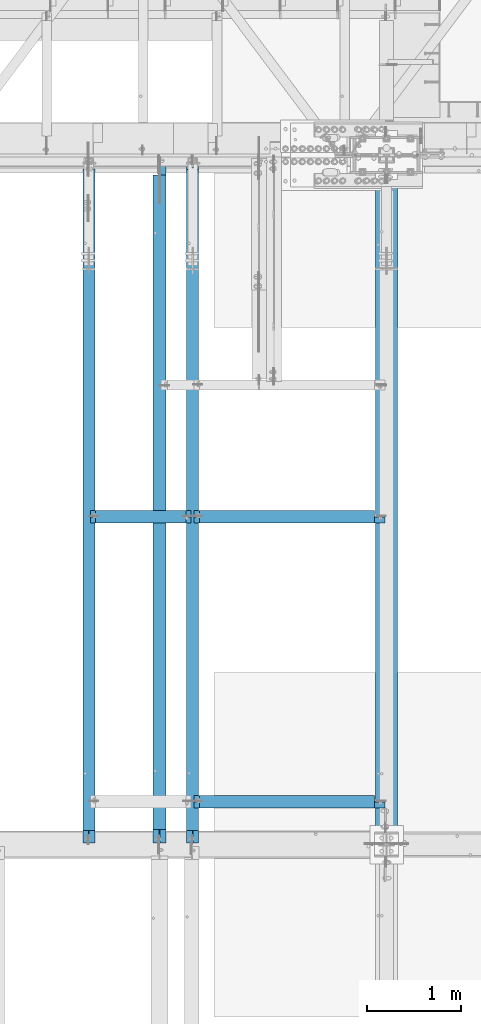
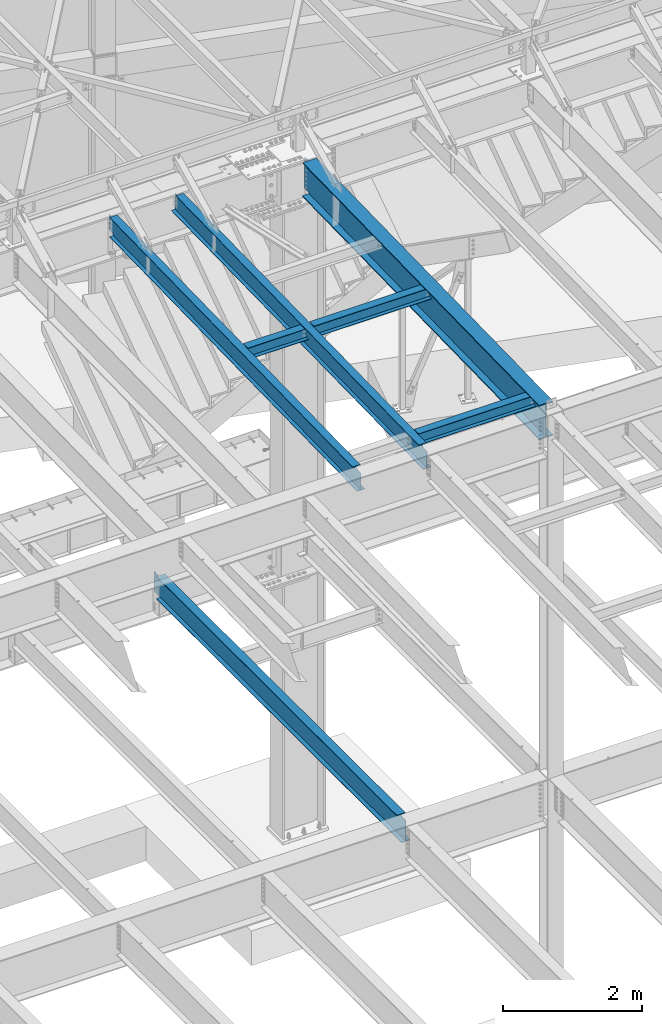
# One storey, part 1143 of 1763: 7 beams, 7 elements without a shape of their own.
"""IFC2X3 building model written with IfcOpenShell, lengths in millimetres."""

from ifc_helpers import new_model, si_unit, frame, origin_with_axes, place, context, subcontext, project, spatial, faceted_brep, material, type_object, element, aggregate, save


model = new_model("IFC2X3")

# Units and contexts
model_context = context("Model", 3, precision=1e-05, world=origin_with_axes())
body_context = subcontext(model_context, "Body", "Model", "MODEL_VIEW")
ifc_project = project(units=[si_unit("LENGTHUNIT", "METRE", prefix="MILLI"), si_unit("AREAUNIT", "SQUARE_METRE"), si_unit("VOLUMEUNIT", "CUBIC_METRE"), si_unit("MASSUNIT", "GRAM", prefix="KILO"), si_unit("TIMEUNIT", "SECOND"), si_unit("PLANEANGLEUNIT", "RADIAN"), si_unit("SOLIDANGLEUNIT", "STERADIAN"), si_unit("THERMODYNAMICTEMPERATUREUNIT", "DEGREE_CELSIUS"), si_unit("LUMINOUSINTENSITYUNIT", "LUMEN")], contexts=[model_context])

# Site, building, storey
site_placement = place(None, origin_with_axes())
site = spatial("IfcSite", under=ifc_project, at=site_placement, CompositionType="ELEMENT")
building_placement = place(site_placement, origin_with_axes())
building = spatial("IfcBuilding", under=site, at=building_placement, Name="Undefined", CompositionType="ELEMENT")
storey_placement = place(building_placement, origin_with_axes())
storey = spatial("IfcBuildingStorey", under=building, at=storey_placement, Name="Undefined", CompositionType="ELEMENT", Elevation=0.0)

# Assembly, beam
assembly_1_placement = place(storey_placement, origin_with_axes())
assembly_1 = element("IfcElementAssembly", 1, at=assembly_1_placement, inside=storey, Name="BEAM", AssemblyPlace="NOTDEFINED", PredefinedType="RIGID_FRAME")
ifc_material = material(Name="STEEL/A992")
beam_type_1 = type_object("IfcBeamType", Name="W8X18", PredefinedType="NOTDEFINED")
beam_1_placement = place(assembly_1_placement, frame((-38107.8885203322, 48285.4, 11564.9593897416), z_axis=(0.0, 0.0, 1.0), x_axis=(1.0, 0.0, 0.0)))
beam_1 = element("IfcBeam", 2, at=beam_1_placement, type_object=beam_type_1, material=ifc_material, Name="BEAM", ObjectType="W8X18", context=body_context, shape_type="Brep", body=[
    faceted_brep([(1028.83123168945, 66.6750000000029, 95.25), (1028.83123168945, 3.17500000000291, 95.25), (73.0250000000015, 3.17500000000291, 95.25), (73.0250000000015, 66.6750000000029, 95.25), (15.8750019335712, -66.675000000032, -95.25), (15.8750019335712, -66.675000000032, -103.1875), (1085.98123168945, -66.6750000000029, -103.1875), (1085.98123168945, -66.6750000000029, -95.25), (15.875, -6.52466826784075, -103.1875), (15.875, 61.6753289071276, -103.1875), (15.8749980664215, 66.6749999999665, -103.1875), (1085.98123168945, 66.6750000000029, -103.1875), (1085.98123168945, 6.52466830228514, -103.1875), (1085.98123168945, -61.6753288726832, -103.1875), (15.8749980664215, 66.6749999999665, -95.25), (1085.98123168945, 66.6750000000029, -95.25), (15.875, 61.6746711106171, -95.25), (15.8749999079228, 3.17499999996653, -95.25), (1085.98123168945, 3.17500000000291, -95.25), (1085.98123168945, 6.52532609878836, -95.25), (65.1850797087827, -3.17500000000291, 72.1442315987078), (65.1850797087827, 3.17500000000291, 72.1442315987078), (60.3250001907363, 3.17500000000291, 71.1775016761203), (60.3250001907363, -3.17500000000291, 71.1775016761203), (69.3052561769364, -3.17500000000291, 74.8972454991854), (69.3052561769364, 3.17500000000291, 74.8972454991854), (72.0582700774103, -3.17500000000291, 79.017421967339), (72.0582700774103, 3.17500000000291, 79.017421967339), (73.0250000000015, -3.17500000000291, 83.8775014853854), (73.0250000000015, 3.17500000000291, 83.8775014853854), (1028.83123168945, 3.17500000000291, 83.8775014869243), (1029.79796161204, 3.17500000000291, 79.0174219688779), (1032.55097551252, 3.17500000000291, 74.8972455007242), (1036.67115198067, 3.17500000000291, 72.1442316002467), (1041.53123149872, 3.17500000000291, 71.1775016776592), (1085.98123168945, 3.17500000000291, 71.1775016776592), (1085.98123168945, 3.17500000000291, -91.3182885805927), (15.875, 3.17500000000291, -91.317762344921), (15.875, 3.17500000000291, 71.1775016761203), (15.875, -3.17500000000291, 71.1775016761203), (15.875, -6.52532606434397, -95.25), (15.87500009207, -3.17500000003201, -95.25), (15.875, -3.17500000000291, -91.3182885821243), (1085.98123168945, -3.17500000000291, -95.25), (1085.98123168945, -3.17500000000291, -91.3177623433876), (1085.98123168945, -3.17500000000291, 71.1775016776592), (1041.53123149872, -3.17500000000291, 71.1775016776592), (1036.67115198067, -3.17500000000291, 72.1442316002467), (1032.55097551252, -3.17500000000291, 74.8972455007242), (1029.79796161204, -3.17500000000291, 79.0174219688779), (1028.83123168945, -3.17500000000291, 83.8775014869243), (1028.83123168945, -3.17500000000291, 95.25), (73.0250000000015, -3.17500000000291, 95.25), (1028.83123168945, -66.6750000000029, 103.1875), (1028.83123168945, 66.6750000000029, 103.1875), (73.0250000000015, 66.6750000000029, 103.1875), (73.0250000000015, -66.6750000000029, 103.024323119123), (1028.83123168945, -66.6750000000029, 95.25), (73.0250000000015, -66.6750000000029, 95.25), (1085.98123168945, -61.6746710761727, -95.25)], [[[0, 1, 2, 3]], [[4, 5, 6, 7]], [[5, 8, 9, 10, 11, 12, 13, 6]], [[10, 14, 15, 11]], [[14, 16, 17, 18, 19, 15]], [[20, 21, 22, 23]], [[24, 25, 21, 20]], [[26, 27, 25, 24]], [[28, 29, 27, 26]], [[1, 30, 31, 32, 33, 34, 35, 36, 18, 17, 37, 38, 22, 21, 25, 27, 29, 2]], [[23, 22, 38, 39]], [[37, 17, 16, 14, 10, 9, 8, 5, 4, 40, 41, 42, 39, 38]], [[26, 24, 20, 23, 39, 42, 41, 43, 44, 45, 46, 47, 48, 49, 50, 51, 52, 28]], [[53, 54, 55, 56]], [[57, 53, 56, 58]], [[51, 57, 58, 52]], [[56, 55, 3, 2, 29, 28, 52, 58]], [[54, 0, 3, 55]], [[53, 57, 51, 50, 30, 1, 0, 54]], [[49, 31, 30, 50]], [[48, 32, 31, 49]], [[47, 33, 32, 48]], [[46, 34, 33, 47]], [[45, 35, 34, 46]], [[44, 43, 59, 7, 6, 13, 12, 11, 15, 19, 18, 36, 35, 45]], [[41, 40, 4, 7, 59, 43]]]),
])
aggregate(assembly_1, [beam_1])

assembly_2_placement = place(storey_placement, origin_with_axes())
assembly_2 = element("IfcElementAssembly", 3, at=assembly_2_placement, inside=storey, Name="BEAM", AssemblyPlace="NOTDEFINED", PredefinedType="RIGID_FRAME")
beam_2_placement = place(assembly_2_placement, frame((-37006.0322886427, 48285.4, 11564.9593897416), z_axis=(0.0, 0.0, 1.0), x_axis=(1.0, 0.0, 0.0)))
beam_2 = element("IfcBeam", 4, at=beam_2_placement, type_object=beam_type_1, material=ifc_material, Name="BEAM", ObjectType="W8X18", context=body_context, shape_type="Brep", body=[
    faceted_brep([(73.0250000000015, 3.17500000000291, 95.25), (73.0250000000015, 66.6750000000029, 95.25), (1929.98876494438, 66.6750000000029, 95.25), (1929.98876494438, 3.17500000000291, 95.25), (73.0250000000015, -66.6750000000029, 103.023408127618), (73.0250000000015, 66.6750000000029, 103.1875), (73.0250000000015, 3.17500000000291, 83.8775014853854), (73.0250000000015, -3.17500000000291, 83.8775014853854), (73.0250000000015, -3.17500000000291, 95.25), (73.0250000000015, -66.6750000000029, 95.25), (72.0582700774103, 3.17500000000291, 79.017421967339), (72.0582700774103, -3.17500000000291, 79.017421967339), (69.3052561769364, 3.17500000000291, 74.8972454991854), (69.3052561769364, -3.17500000000291, 74.8972454991854), (65.1850797087827, 3.17500000000291, 72.1442315987078), (65.1850797087827, -3.17500000000291, 72.1442315987078), (60.3250001907363, 3.17500000000291, 71.1775016761203), (60.3250001907363, -3.17500000000291, 71.1775016761203), (15.87500009207, -3.17500000003201, -95.25), (15.875, -6.52517323475331, -95.25), (15.8750019335712, -66.675000000032, -95.25), (2037.93876494438, -66.6750000000029, -95.25), (2037.93876494438, -3.17500000000291, -95.25), (15.8750019335712, -66.675000000032, -103.1875), (2037.93876494438, -66.6750000000029, -103.1875), (2037.93876494438, 3.17500000000291, -95.25), (2037.93876494438, 3.17500000000291, 58.4775016773747), (2037.93876494438, -3.17500000000291, 58.4775016773747), (2037.93876494438, 3.47492408267135, -103.1875), (2037.93876494438, 3.47522508854308, -95.25), (1937.8286852356, -3.17500000000291, 59.4442315999622), (1933.70850876745, -3.17500000000291, 62.1972455004397), (1930.95549486698, -3.17500000000291, 66.3174219685934), (1929.98876494438, -3.17500000000291, 71.1775014866398), (1929.98876494438, -3.17500000000291, 95.25), (15.875, -3.17500000000291, 71.1775016761203), (15.875, -3.17500000000291, -91.3156018956779), (1942.68876475365, -3.17500000000291, 58.4775016773747), (1929.98876494438, -66.6750000000029, 95.25), (1929.98876494438, -66.6750000000029, 103.178484989805), (1929.98876494438, 66.6750000000029, 103.1875), (1929.98876494438, 3.17500000000291, 71.1775014866398), (1930.95549486698, 3.17500000000291, 66.3174219685934), (1933.70850876745, 3.17500000000291, 62.1972455004397), (1937.8286852356, 3.17500000000291, 59.4442315999622), (1942.68876475365, 3.17500000000291, 58.4775016773747), (15.8749999079228, 3.17499999996653, -95.25), (15.875, 3.17500000000291, -91.3153199048811), (15.875, 3.17500000000291, 71.1775016761203), (15.875, 61.6748237785141, -95.25), (15.8749980664215, 66.6749999999665, -95.25), (15.8749980664215, 66.6749999999665, -103.1875), (15.875, 61.6751762670101, -103.1875), (15.875, -6.52482074625732, -103.1875), (1929.98867639694, 66.6750000000029, -103.1875), (1929.98871823565, 3.4748526194162, -103.1875), (1929.98871823547, 3.47515362528793, -95.25), (1929.98867639694, 66.6750000000029, -95.25)], [[[0, 1, 2, 3]], [[4, 5, 1, 0, 6, 7, 8, 9]], [[7, 6, 10, 11]], [[11, 10, 12, 13]], [[13, 12, 14, 15]], [[15, 14, 16, 17]], [[18, 19, 20, 21, 22]], [[20, 23, 24, 21]], [[25, 26, 27, 22, 21, 24, 28, 29]], [[30, 31, 32, 33, 34, 8, 7, 11, 13, 15, 17, 35, 36, 18, 22, 27, 37]], [[9, 8, 34, 38]], [[4, 9, 38, 39]], [[5, 4, 39, 40]], [[1, 5, 40, 2]], [[39, 38, 34, 33, 41, 3, 2, 40]], [[32, 42, 41, 33]], [[31, 43, 42, 32]], [[30, 44, 43, 31]], [[37, 45, 44, 30]], [[27, 26, 45, 37]], [[25, 46, 47, 48, 16, 14, 12, 10, 6, 0, 3, 41, 42, 43, 44, 45, 26]], [[17, 16, 48, 35]], [[47, 46, 49, 50, 51, 52, 53, 23, 20, 19, 18, 36, 35, 48]], [[24, 23, 53, 52, 51, 54, 55, 28]], [[29, 28, 55, 56]], [[57, 50, 49, 46, 25, 29, 56]], [[51, 50, 57, 54]], [[56, 55, 54, 57]]]),
])
aggregate(assembly_2, [beam_2])

assembly_3_placement = place(storey_placement, origin_with_axes())
assembly_3 = element("IfcElementAssembly", 5, at=assembly_3_placement, inside=storey, Name="BEAM", AssemblyPlace="NOTDEFINED", PredefinedType="RIGID_FRAME")
beam_3_placement = place(assembly_3_placement, frame((-37006.0322886427, 45262.8, 11502.4228391437), z_axis=(0.0, 0.0, 1.0), x_axis=(1.0, 0.0, 0.0)))
beam_3 = element("IfcBeam", 6, at=beam_3_placement, type_object=beam_type_1, material=ifc_material, Name="BEAM", ObjectType="W8X18", context=body_context, shape_type="Brep", body=[
    faceted_brep([(73.0250000000015, 3.17500000000291, 95.25), (73.0250000000015, 66.6750000000029, 95.25), (1929.98876494438, 66.6750000000029, 95.25), (1929.98876494438, 3.17500000000291, 95.25), (73.0250000000015, -66.6750000000029, 103.023408127618), (73.0250000000015, 66.6750000000029, 103.1875), (73.0250000000015, 3.17500000000291, 83.8775014853854), (73.0250000000015, -3.17500000000291, 83.8775014853854), (73.0250000000015, -3.17500000000291, 95.25), (73.0250000000015, -66.6750000000029, 95.25), (72.0582700774103, 3.17500000000291, 79.017421967339), (72.0582700774103, -3.17500000000291, 79.017421967339), (69.3052561769364, 3.17500000000291, 74.8972454991854), (69.3052561769364, -3.17500000000291, 74.8972454991854), (65.1850797087827, 3.17500000000291, 72.1442315987078), (65.1850797087827, -3.17500000000291, 72.1442315987078), (60.3250001907363, 3.17500000000291, 71.1775016761203), (60.3250001907363, -3.17500000000291, 71.1775016761203), (15.87500009207, -3.17500000003201, -95.25), (15.875, -6.52517323475331, -95.25), (15.8750019335712, -66.675000000032, -95.25), (2037.93876494438, -66.6750000000029, -95.25), (2037.93876494438, -3.17500000000291, -95.25), (15.8750019335712, -66.675000000032, -103.1875), (2037.93876494438, -66.6750000000029, -103.1875), (2037.93876494438, 3.17500000000291, -95.25), (2037.93876494438, 3.17500000000291, 58.4775016773747), (2037.93876494438, -3.17500000000291, 58.4775016773747), (2037.93876494438, 3.47492408267135, -103.1875), (2037.93876494438, 3.47522508854308, -95.25), (1937.8286852356, -3.17500000000291, 59.4442315999622), (1933.70850876745, -3.17500000000291, 62.1972455004397), (1930.95549486698, -3.17500000000291, 66.3174219685934), (1929.98876494438, -3.17500000000291, 71.1775014866398), (1929.98876494438, -3.17500000000291, 95.25), (15.875, -3.17500000000291, 71.1775016761203), (15.875, -3.17500000000291, -91.3156018956779), (1942.68876475365, -3.17500000000291, 58.4775016773747), (1929.98876494438, -66.6750000000029, 95.25), (1929.98876494438, -66.6750000000029, 103.178484989805), (1929.98876494438, 66.6750000000029, 103.1875), (1929.98876494438, 3.17500000000291, 71.1775014866398), (1930.95549486698, 3.17500000000291, 66.3174219685934), (1933.70850876745, 3.17500000000291, 62.1972455004397), (1937.8286852356, 3.17500000000291, 59.4442315999622), (1942.68876475365, 3.17500000000291, 58.4775016773747), (15.8749999079228, 3.17499999996653, -95.25), (15.875, 3.17500000000291, -91.3153199048811), (15.875, 3.17500000000291, 71.1775016761203), (15.875, 61.6748237785141, -95.25), (15.8749980664215, 66.6749999999665, -95.25), (15.8749980664215, 66.6749999999665, -103.1875), (15.875, 61.6751762670101, -103.1875), (15.875, -6.52482074625732, -103.1875), (1929.98867639694, 66.6750000000029, -103.1875), (1929.98871823565, 3.4748526194162, -103.1875), (1929.98871823547, 3.47515362528793, -95.25), (1929.98867639694, 66.6750000000029, -95.25)], [[[0, 1, 2, 3]], [[4, 5, 1, 0, 6, 7, 8, 9]], [[7, 6, 10, 11]], [[11, 10, 12, 13]], [[13, 12, 14, 15]], [[15, 14, 16, 17]], [[18, 19, 20, 21, 22]], [[20, 23, 24, 21]], [[25, 26, 27, 22, 21, 24, 28, 29]], [[30, 31, 32, 33, 34, 8, 7, 11, 13, 15, 17, 35, 36, 18, 22, 27, 37]], [[9, 8, 34, 38]], [[4, 9, 38, 39]], [[5, 4, 39, 40]], [[1, 5, 40, 2]], [[39, 38, 34, 33, 41, 3, 2, 40]], [[32, 42, 41, 33]], [[31, 43, 42, 32]], [[30, 44, 43, 31]], [[37, 45, 44, 30]], [[27, 26, 45, 37]], [[25, 46, 47, 48, 16, 14, 12, 10, 6, 0, 3, 41, 42, 43, 44, 45, 26]], [[17, 16, 48, 35]], [[47, 46, 49, 50, 51, 52, 53, 23, 20, 19, 18, 36, 35, 48]], [[24, 23, 53, 52, 51, 54, 55, 28]], [[29, 28, 55, 56]], [[57, 50, 49, 46, 25, 29, 56]], [[51, 50, 57, 54]], [[56, 55, 54, 57]]]),
])
aggregate(assembly_3, [beam_3])

assembly_4_placement = place(storey_placement, origin_with_axes())
assembly_4 = element("IfcElementAssembly", 7, at=assembly_4_placement, inside=storey, Name="BEAM", AssemblyPlace="NOTDEFINED", PredefinedType="RIGID_FRAME")
beam_type_2 = type_object("IfcBeamType", Name="W16X26", PredefinedType="NOTDEFINED")
beam_4_placement = place(assembly_4_placement, frame((-37358.603940365, 44805.6, 4994.275), z_axis=(0.0, 0.0, 1.0), x_axis=(0.0, 1.0, 0.0)))
beam_4 = element("IfcBeam", 8, at=beam_4_placement, type_object=beam_type_2, material=ifc_material, Name="BEAM", ObjectType="W16X26", context=body_context, shape_type="Brep", body=[
    faceted_brep([(7104.06248869727, 3.17500000000291, -190.5), (7104.06248869734, 3.17487653380522, -200.025), (7104.06247902929, 69.8499999999985, -200.025), (7104.06247902929, 69.8499999999985, -190.5), (7294.5625, 3.17500000000291, -190.5), (7294.5625, 3.17490415680368, -200.025), (159.543749432261, 3.17500000000291, 190.5), (159.543749432261, 69.8499999999985, 190.5), (7104.0625, 69.8499999999985, 190.5), (7104.0625, 3.17500000000291, 190.5), (159.543749432261, -69.8499999999985, 200.025), (159.543749432261, 69.8499999999985, 200.025), (159.543749432261, 3.17500000000291, 180.715001487732), (159.543749432261, -3.17500000000291, 180.715001487732), (159.543749432261, -3.17500000000291, 190.5), (159.543749432261, -69.8499999999985, 190.5), (158.57701950967, 3.17500000000291, 175.854921969686), (158.57701950967, -3.17500000000291, 175.854921969686), (155.824005609196, 3.17500000000291, 171.734745501532), (155.824005609196, -3.17500000000291, 171.734745501532), (151.703829141043, 3.17500000000291, 168.981731601054), (151.703829141043, -3.17500000000291, 168.981731601054), (146.843749622996, 3.17500000000291, 168.015001678466), (146.843749622996, -3.17500000000291, 168.015001678466), (19.84375, 3.17500000000291, 168.015001678466), (19.84375, -3.17500000000291, 168.015001678466), (19.84375, 3.17500000000291, -190.5), (19.84375, 69.8499999999985, -190.5), (19.84375, 69.8499999999985, -200.025), (19.84375, -69.8499999999985, -200.025), (19.84375, -69.8499999999985, -190.5), (19.84375, -3.17500000000291, -190.5), (7294.5625, -69.8499999999985, -200.025), (7294.5625, -69.8499999999985, -190.5), (7294.5625, -3.17500000000291, -190.5), (7111.90242029122, -3.17500000000291, 156.541729922587), (7107.78224382307, -3.17500000000291, 159.294743823066), (7105.02922992258, -3.17500000000291, 163.414920291219), (7104.0625, -3.17500000000291, 168.274999809265), (7104.0625, -3.17500000000291, 190.5), (7294.5625, -3.17500000000291, 155.575), (7116.76249980927, -3.17500000000291, 155.575), (7104.0625, -69.8499999999985, 190.5), (7104.0625, -69.8499999999985, 200.025), (7104.0625, 69.8499999999985, 200.025), (7104.0625, 3.17500000000291, 168.274999809265), (7105.02922992258, 3.17500000000291, 163.414920291219), (7107.78224382307, 3.17500000000291, 159.294743823066), (7111.90242029122, 3.17500000000291, 156.541729922587), (7116.76249980927, 3.17500000000291, 155.575), (7294.5625, 3.17500000000291, 155.575), (7294.5625, 3.17500000000291, -184.976846570121)], [[[0, 1, 2, 3]], [[4, 5, 1, 0]], [[6, 7, 8, 9]], [[10, 11, 7, 6, 12, 13, 14, 15]], [[13, 12, 16, 17]], [[17, 16, 18, 19]], [[19, 18, 20, 21]], [[21, 20, 22, 23]], [[23, 22, 24, 25]], [[26, 27, 28, 29, 30, 31, 25, 24]], [[30, 29, 32, 33]], [[31, 30, 33, 34]], [[35, 36, 37, 38, 39, 14, 13, 17, 19, 21, 23, 25, 31, 34, 40, 41]], [[15, 14, 39, 42]], [[10, 15, 42, 43]], [[11, 10, 43, 44]], [[7, 11, 44, 8]], [[43, 42, 39, 38, 45, 9, 8, 44]], [[37, 46, 45, 38]], [[36, 47, 46, 37]], [[35, 48, 47, 36]], [[41, 49, 48, 35]], [[40, 50, 49, 41]], [[51, 4, 0, 26, 24, 22, 20, 18, 16, 12, 6, 9, 45, 46, 47, 48, 49, 50]], [[27, 26, 0, 3]], [[28, 27, 3, 2]], [[32, 29, 28, 2, 1, 5]], [[51, 50, 40, 34, 33, 32, 5, 4]]]),
])
aggregate(assembly_4, [beam_4])

assembly_5_placement = place(storey_placement, origin_with_axes())
assembly_5 = element("IfcElementAssembly", 9, at=assembly_5_placement, inside=storey, Name="BEAM", AssemblyPlace="NOTDEFINED", PredefinedType="RIGID_FRAME")
beam_type_3 = type_object("IfcBeamType", Name="W14X22", PredefinedType="NOTDEFINED")
beam_5_placement = place(assembly_5_placement, frame((-38107.8885203322, 44809.2121576992, 11421.5633921212), z_axis=(0.0, -0.0206852279954837, 0.999786037781472), x_axis=(0.0, 0.999786037781472, 0.0206852279954825)))
beam_5 = element("IfcBeam", 10, at=beam_5_placement, type_object=beam_type_3, material=ifc_material, Name="BEAM", ObjectType="W14X22", context=body_context, shape_type="Brep", body=[
    faceted_brep([(7162.77359555585, -3.17500000000291, -166.687500001777), (7162.77359555585, -63.5, -166.687500001777), (7162.77359555585, -63.5, -174.625000001772), (7162.77359555585, 63.5, -174.625000001772), (7162.77359555585, 63.5, -166.687500001777), (7162.77359555585, 3.17500000000291, -166.687500001777), (7162.77359555586, 3.17500000000291, -155.574999838074), (7162.77359555586, -3.17500000000291, -155.574999838074), (7163.74032547845, 3.17500000000291, -150.714920320039), (7163.74032547845, -3.17500000000291, -150.714920320039), (7166.49333937895, 3.17500000000291, -146.594743851894), (7166.49333937895, -3.17500000000291, -146.594743851894), (7170.61351584714, 3.17500000000291, -143.841729951426), (7170.61351584714, -3.17500000000291, -143.841729951426), (7175.47359536523, 3.17500000000291, -142.87500002884), (7175.47359536523, -3.17500000000291, -142.87500002884), (7289.55462988591, -3.17500000000291, -142.875000028898), (7289.55462988591, 3.17500000000291, -142.875000028898), (148.791145859177, 3.17500000000291, 166.687499999833), (148.791145859177, 63.5, 166.687499999833), (7169.123595556, 63.5, 166.68749999797), (7169.123595556, 3.17500000000291, 166.68749999797), (11.9924390219312, 3.17500000000291, -166.687499999878), (11.9924390219312, 63.5, -166.687499999878), (11.8282148869548, 63.5, -174.624999999871), (11.8282148869548, -63.5, -174.624999999871), (11.9924390219312, -63.5, -166.687499999878), (11.9924390219312, -3.17500000000291, -166.687499999878), (17.9976630864912, -3.17500000000291, 123.56500167838), (17.9976630864912, 3.17500000000291, 123.56500167838), (136.091146049795, -3.17500000000291, 123.565001678358), (136.091146049795, 3.17500000000291, 123.565001678358), (140.951225567893, -3.17500000000291, 124.531731600942), (140.951225567893, 3.17500000000291, 124.531731600942), (145.071402036083, -3.17500000000291, 127.284745501414), (145.071402036083, 3.17500000000291, 127.284745501414), (147.824415936586, -3.17500000000291, 131.404921969557), (147.824415936586, 3.17500000000291, 131.404921969557), (148.791145859177, -3.17500000000291, 136.265001487593), (148.791145859177, 3.17500000000291, 136.265001487593), (148.79114585917, -63.5, 174.624999999827), (148.79114585917, 63.5, 174.624999999827), (148.791145859177, -3.17500000000291, 166.687499999833), (148.791145859177, -63.5, 166.687499999833), (7169.123595556, -3.17500000000291, 166.68749999797), (7169.123595556, -63.5, 166.68749999797), (7169.123595556, -63.5, 174.624999997965), (7169.123595556, 63.5, 174.624999997965), (7169.123595556, -3.17500000000291, 142.875000542512), (7169.123595556, 3.17500000000291, 142.875000542512), (7170.0903254786, -3.17500000000291, 138.014921024478), (7170.0903254786, 3.17500000000291, 138.014921024478), (7172.8433393791, -3.17500000000291, 133.894744556334), (7172.8433393791, 3.17500000000291, 133.894744556334), (7176.96351584728, -3.17500000000291, 131.14173065586), (7176.96351584728, 3.17500000000291, 131.14173065586), (7181.82359536537, -3.17500000000291, 130.175000733272), (7181.82359536537, 3.17500000000291, 130.175000733272), (7295.20394014482, -3.17500000000291, 130.17500073325), (7295.20394014482, 3.17500000000291, 130.17500073325)], [[[0, 1, 2, 3, 4, 5, 6, 7]], [[7, 6, 8, 9]], [[9, 8, 10, 11]], [[11, 10, 12, 13]], [[13, 12, 14, 15]], [[16, 15, 14, 17]], [[18, 19, 20, 21]], [[22, 23, 24, 25, 26, 27, 28, 29]], [[30, 31, 29, 28]], [[32, 33, 31, 30]], [[34, 35, 33, 32]], [[36, 37, 35, 34]], [[38, 39, 37, 36]], [[40, 41, 19, 18, 39, 38, 42, 43]], [[43, 42, 44, 45]], [[40, 43, 45, 46]], [[41, 40, 46, 47]], [[19, 41, 47, 20]], [[46, 45, 44, 48, 49, 21, 20, 47]], [[50, 51, 49, 48]], [[52, 53, 51, 50]], [[54, 55, 53, 52]], [[56, 57, 55, 54]], [[58, 59, 57, 56]], [[59, 58, 16, 17]], [[12, 10, 8, 6, 5, 22, 29, 31, 33, 35, 37, 39, 18, 21, 49, 51, 53, 55, 57, 59, 17, 14]], [[23, 22, 5, 4]], [[24, 23, 4, 3]], [[25, 24, 3, 2]], [[26, 25, 2, 1]], [[27, 26, 1, 0]], [[58, 56, 54, 52, 50, 48, 44, 42, 38, 36, 34, 32, 30, 28, 27, 0, 7, 9, 11, 13, 15, 16]]]),
])
aggregate(assembly_5, [beam_5])

assembly_6_placement = place(storey_placement, origin_with_axes())
assembly_6 = element("IfcElementAssembly", 11, at=assembly_6_placement, inside=storey, Name="BEAM", AssemblyPlace="NOTDEFINED", PredefinedType="RIGID_FRAME")
beam_6_placement = place(assembly_6_placement, frame((-37006.0322886427, 44809.2121576993, 11421.5633921212), z_axis=(0.0, -0.0206852279954837, 0.999786037781472), x_axis=(0.0, 0.999786037781472, 0.0206852279954825)))
beam_6 = element("IfcBeam", 12, at=beam_6_placement, type_object=beam_type_3, material=ifc_material, Name="BEAM", ObjectType="W14X22", context=body_context, shape_type="Brep", body=[
    faceted_brep([(136.091146049795, -3.17500000000291, 123.565001678358), (136.091146049795, 3.17500000000291, 123.565001678358), (17.9976630864912, 3.17500000000291, 123.56500167838), (17.9976630864912, -3.17500000000291, 123.56500167838), (140.951225567893, -3.17500000000291, 124.531731600942), (140.951225567893, 3.17500000000291, 124.531731600942), (145.071402036083, -3.17500000000291, 127.284745501414), (145.071402036083, 3.17500000000291, 127.284745501414), (147.824415936586, -3.17500000000291, 131.404921969557), (147.824415936586, 3.17500000000291, 131.404921969557), (148.791145859177, -3.17500000000291, 136.265001487593), (148.791145859177, 3.17500000000291, 136.265001487593), (148.79114585917, -63.5, 174.624999999827), (148.79114585917, 63.5, 174.624999999827), (148.791145859177, 63.5, 166.687499999833), (148.791145859177, 3.17500000000291, 166.687499999833), (148.791145859177, -3.17500000000291, 166.687499999833), (148.791145859177, -63.5, 166.687499999833), (11.9924390219312, -3.17500000000291, -166.687499999878), (11.9924390219312, -63.5, -166.687499999878), (7289.06195724197, -63.5, -166.687500001812), (7289.06195724197, -3.17500000000291, -166.687500001812), (11.8282148869548, -63.5, -174.624999999871), (7288.89773310699, -63.5, -174.625000001806), (11.8282148869548, 63.5, -174.624999999871), (7288.89773310699, 63.5, -174.625000001806), (11.9924390219312, 63.5, -166.687499999878), (7289.06195724197, 63.5, -166.687500001812), (11.9924390219312, 3.17500000000291, -166.687499999878), (7289.06195724197, 3.17500000000291, -166.687500001812), (7294.93580191941, 3.17500000000291, 117.21499785159), (7294.93580191941, -3.17500000000291, 117.21499785159), (7178.21066392501, 3.17500000000291, 117.214997851612), (7178.21066392501, -3.17500000000291, 117.214997851612), (7173.35058440694, 3.17500000000291, 118.181727774199), (7173.35058440694, -3.17500000000291, 118.181727774199), (7169.23040793875, 3.17500000000291, 120.934741674671), (7169.23040793875, -3.17500000000291, 120.934741674671), (7166.47739403824, 3.17500000000291, 125.054918142816), (7166.47739403824, -3.17500000000291, 125.054918142816), (7165.51066411565, 3.17500000000291, 129.91499766085), (7165.51066411565, -3.17500000000291, 129.91499766085), (7165.51066411565, -63.5, 174.624999997965), (7165.51066411565, -63.5, 166.68749999797), (7165.51066411565, -3.17500000000291, 166.68749999797), (7165.51066411565, 3.17500000000291, 166.68749999797), (7165.51066411565, 63.5, 166.68749999797), (7165.51066411565, 63.5, 174.624999997965)], [[[0, 1, 2, 3]], [[4, 5, 1, 0]], [[6, 7, 5, 4]], [[8, 9, 7, 6]], [[10, 11, 9, 8]], [[12, 13, 14, 15, 11, 10, 16, 17]], [[18, 19, 20, 21]], [[19, 22, 23, 20]], [[22, 24, 25, 23]], [[24, 26, 27, 25]], [[26, 28, 29, 27]], [[21, 20, 23, 25, 27, 29, 30, 31]], [[31, 30, 32, 33]], [[33, 32, 34, 35]], [[35, 34, 36, 37]], [[37, 36, 38, 39]], [[39, 38, 40, 41]], [[42, 43, 44, 41, 40, 45, 46, 47]], [[43, 42, 12, 17]], [[44, 43, 17, 16]], [[8, 6, 4, 0, 3, 18, 21, 31, 33, 35, 37, 39, 41, 44, 16, 10]], [[28, 26, 24, 22, 19, 18, 3, 2]], [[45, 40, 38, 36, 34, 32, 30, 29, 28, 2, 1, 5, 7, 9, 11, 15]], [[46, 45, 15, 14]], [[47, 46, 14, 13]], [[42, 47, 13, 12]]]),
])
aggregate(assembly_6, [beam_6])

assembly_7_placement = place(storey_placement, origin_with_axes())
assembly_7 = element("IfcElementAssembly", 13, at=assembly_7_placement, inside=storey, Name="BEAM", AssemblyPlace="NOTDEFINED", PredefinedType="RIGID_FRAME")
beam_type_4 = type_object("IfcBeamType", Name="W24X76", PredefinedType="NOTDEFINED")
beam_7_placement = place(assembly_7_placement, frame((-34949.8372736984, 44811.8720196671, 11293.0034049879), z_axis=(0.0, -0.0206852279954837, 0.999786037781472), x_axis=(0.0, 0.999786037781472, 0.0206852279954825)))
beam_7 = element("IfcBeam", 14, at=beam_7_placement, type_object=beam_type_4, material=ifc_material, Name="BEAM", ObjectType="W24X76", context=body_context, shape_type="Brep", body=[
    faceted_brep([(6970.7229836276, -5.55625000000146, -285.750000001635), (6970.7229836276, -114.300000000003, -285.750000001635), (6970.72298362759, -114.300000000003, -303.212500001624), (6970.72298362759, 114.300000000003, -303.212500001624), (6970.7229836276, 114.300000000003, -285.750000001635), (6970.7229836276, 5.55625000000146, -285.750000001635), (6970.7229836276, 5.55625000000146, -284.422499820606), (6970.7229836276, -5.55625000000146, -284.422499820606), (6971.6897135502, 5.55625000000146, -279.562420302573), (6971.6897135502, -5.55625000000146, -279.562420302573), (6974.4427274507, 5.55625000000146, -275.442243834428), (6974.4427274507, -5.55625000000146, -275.442243834428), (6978.56290391889, 5.55625000000146, -272.68922993396), (6978.56290391889, -5.55625000000146, -272.68922993396), (6983.42298343699, 5.55625000000146, -271.722500011376), (6983.42298343699, -5.55625000000146, -271.722500011376), (7098.45113886343, -5.55625000000146, -271.722500011443), (7098.45113886343, 5.55625000000146, -271.722500011443), (144.132123062285, 5.55625000000146, 285.749999999749), (144.132123062285, 114.300000000003, 285.749999999749), (6970.72298362766, 114.300000000003, 285.749999997934), (6970.72298362766, 5.55625000000146, 285.749999997934), (131.946692247155, -114.300000000003, -303.212499999805), (132.307985344094, -114.300000000003, -285.749999999818), (132.307985344094, -5.55625000000146, -285.749999999818), (144.132123062285, -5.55625000000146, 285.749999999749), (144.132123062285, -114.300000000003, 285.749999999749), (144.493416159225, -114.300000000003, 303.212499999736), (144.493416159225, 114.300000000003, 303.212499999736), (132.307985344094, 5.55625000000146, -285.749999999818), (132.307985344094, 114.300000000003, -285.749999999818), (131.946692247155, 114.300000000003, -303.212499999805), (6970.72298362766, -5.55625000000146, 285.749999997934), (6970.72298362766, -114.300000000003, 285.749999997934), (6970.72298362767, -114.300000000003, 303.212499997921), (6970.72298362767, 114.300000000003, 303.212499997921), (6970.72298362767, -5.55625000000146, 283.902501475037), (6970.72298362767, 5.55625000000146, 283.902501475037), (6971.68971355027, -5.55625000000146, 279.042421957003), (6971.68971355027, 5.55625000000146, 279.042421957003), (6974.44272745076, -5.55625000000146, 274.922245488859), (6974.44272745076, 5.55625000000146, 274.922245488859), (6978.56290391896, -5.55625000000146, 272.169231588385), (6978.56290391896, 5.55625000000146, 272.169231588385), (6983.42298343705, -5.55625000000146, 271.202501665797), (6983.42298343705, 5.55625000000146, 271.202501665797), (7109.68406973042, -5.55625000000146, 271.202501665775), (7109.68406973042, 5.55625000000146, 271.202501665775)], [[[0, 1, 2, 3, 4, 5, 6, 7]], [[7, 6, 8, 9]], [[9, 8, 10, 11]], [[11, 10, 12, 13]], [[13, 12, 14, 15]], [[16, 15, 14, 17]], [[18, 19, 20, 21]], [[22, 23, 24, 25, 26, 27, 28, 19, 18, 29, 30, 31]], [[26, 25, 32, 33]], [[27, 26, 33, 34]], [[28, 27, 34, 35]], [[19, 28, 35, 20]], [[34, 33, 32, 36, 37, 21, 20, 35]], [[38, 39, 37, 36]], [[40, 41, 39, 38]], [[42, 43, 41, 40]], [[44, 45, 43, 42]], [[46, 47, 45, 44]], [[47, 46, 16, 17]], [[12, 10, 8, 6, 5, 29, 18, 21, 37, 39, 41, 43, 45, 47, 17, 14]], [[30, 29, 5, 4]], [[31, 30, 4, 3]], [[22, 31, 3, 2]], [[23, 22, 2, 1]], [[24, 23, 1, 0]], [[46, 44, 42, 40, 38, 36, 32, 25, 24, 0, 7, 9, 11, 13, 15, 16]]]),
])
aggregate(assembly_7, [beam_7])

save(model, "model.ifc")
